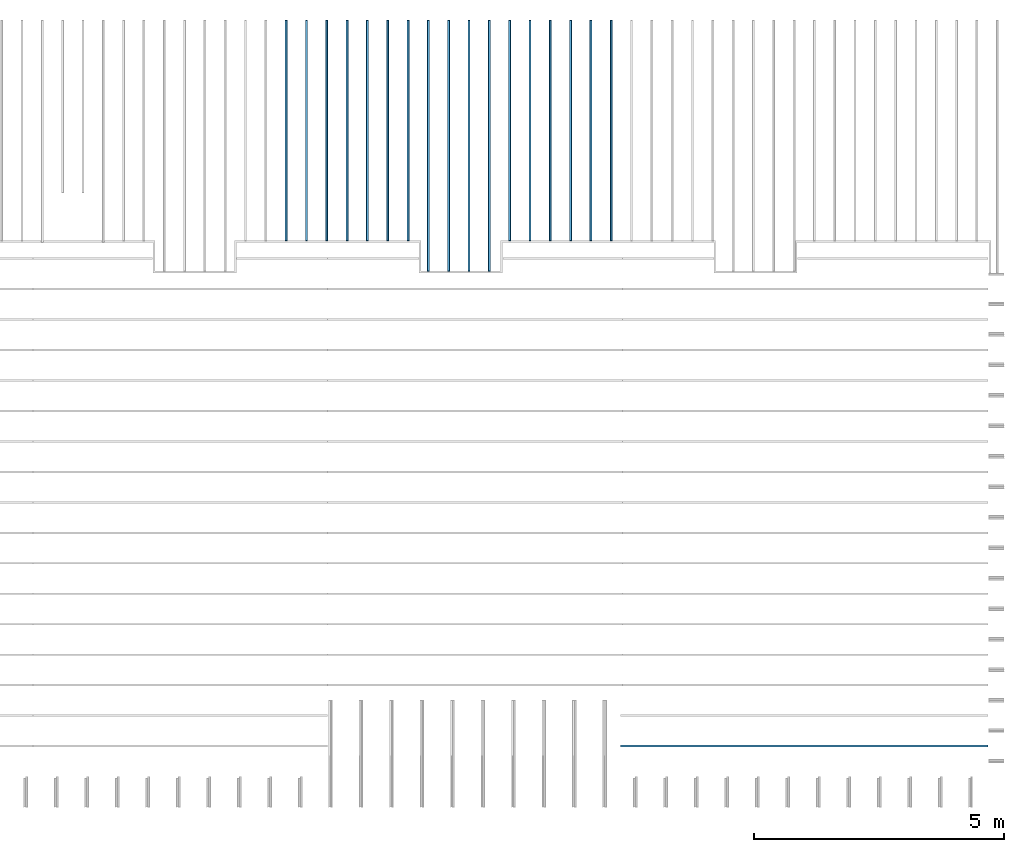
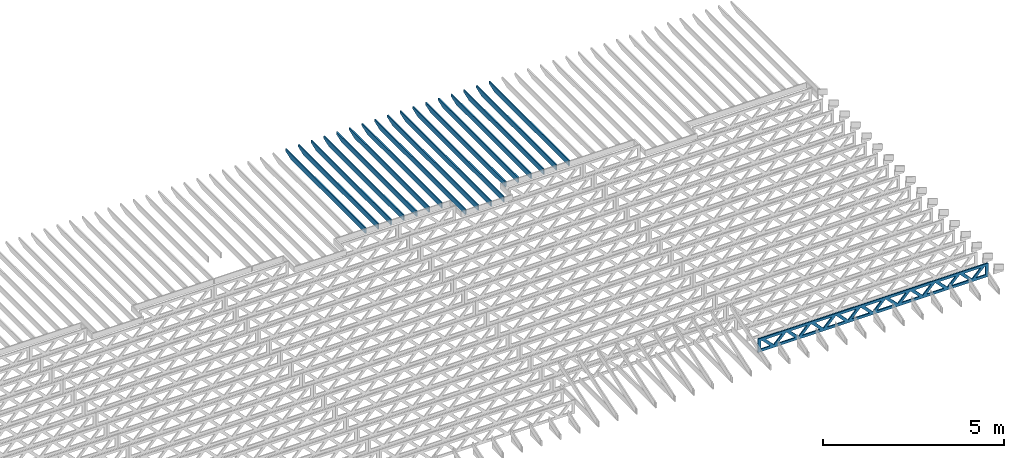
# One storey, part 11 of 18: 18 beams, 2 elements without a shape of their own.
"""IFC4 building model written with IfcOpenShell, lengths in feet."""

from ifc_helpers import new_model, entity, si_unit, converted_unit, derived_unit, direction, frame, frame_2d, origin, origin_2d_with_axis, place, context, subcontext, project, spatial, rectangle, extrude, clip, halfspace, source, transform, mapped, material, material_profile, profile_set, profile_usage, type_object, type_shapes, element, aggregate, save


model = new_model("IFC4")

# Units and contexts
model_context_1 = context("Model", 3, precision=0.0001, world=origin(), true_north=direction((6.12303176911189e-17, 1.0)))
model_context_2 = context("Model", 3, precision=0.0001, world=origin(), true_north=direction((6.12303176911189e-17, 1.0)))
body_context = subcontext(model_context_2, "Body", "Model", "MODEL_VIEW")
ifc_project = project(units=[converted_unit("LENGTHUNIT", "FOOT", entity("IfcRatioMeasure", 0.3048), si_unit("LENGTHUNIT", "METRE"), dimensions=[1, 0, 0, 0, 0, 0, 0]), converted_unit("AREAUNIT", "SQUARE FOOT", entity("IfcRatioMeasure", 0.09290304), si_unit("AREAUNIT", "SQUARE_METRE"), dimensions=[2, 0, 0, 0, 0, 0, 0]), converted_unit("VOLUMEUNIT", "CUBIC FOOT", entity("IfcRatioMeasure", 0.028316846592), si_unit("VOLUMEUNIT", "CUBIC_METRE"), dimensions=[3, 0, 0, 0, 0, 0, 0]), converted_unit("PLANEANGLEUNIT", "DEGREE", entity("IfcRatioMeasure", 0.0174532925199433), si_unit("PLANEANGLEUNIT", "RADIAN"), dimensions=[0, 0, 0, 0, 0, 0, 0]), si_unit("MASSUNIT", "GRAM", prefix="KILO"), derived_unit("MASSDENSITYUNIT", [(si_unit("MASSUNIT", "GRAM", prefix="KILO"), 1), (si_unit("LENGTHUNIT", "METRE"), -3)]), derived_unit("MOMENTOFINERTIAUNIT", [(si_unit("LENGTHUNIT", "METRE"), 4)]), si_unit("TIMEUNIT", "SECOND"), si_unit("FREQUENCYUNIT", "HERTZ"), si_unit("THERMODYNAMICTEMPERATUREUNIT", "DEGREE_CELSIUS"), derived_unit("THERMALTRANSMITTANCEUNIT", [(si_unit("MASSUNIT", "GRAM", prefix="KILO"), 1), (si_unit("THERMODYNAMICTEMPERATUREUNIT", "KELVIN"), -1), (si_unit("TIMEUNIT", "SECOND"), -3)]), derived_unit("VOLUMETRICFLOWRATEUNIT", [(si_unit("LENGTHUNIT", "METRE"), 3), (si_unit("TIMEUNIT", "SECOND"), -1)]), si_unit("ELECTRICCURRENTUNIT", "AMPERE"), si_unit("ELECTRICVOLTAGEUNIT", "VOLT"), si_unit("POWERUNIT", "WATT"), si_unit("FORCEUNIT", "NEWTON"), si_unit("ILLUMINANCEUNIT", "LUX"), si_unit("LUMINOUSFLUXUNIT", "LUMEN"), si_unit("LUMINOUSINTENSITYUNIT", "CANDELA"), derived_unit("USERDEFINED", [(si_unit("MASSUNIT", "GRAM", prefix="KILO"), -1), (si_unit("LENGTHUNIT", "METRE"), -2), (si_unit("TIMEUNIT", "SECOND"), 3), (si_unit("LUMINOUSFLUXUNIT", "LUMEN"), 1)]), derived_unit("LINEARVELOCITYUNIT", [(si_unit("LENGTHUNIT", "METRE"), 1), (si_unit("TIMEUNIT", "SECOND"), -1)]), si_unit("PRESSUREUNIT", "PASCAL"), derived_unit("USERDEFINED", [(si_unit("LENGTHUNIT", "METRE"), -2), (si_unit("MASSUNIT", "GRAM", prefix="KILO"), 1), (si_unit("TIMEUNIT", "SECOND"), -2)]), derived_unit("LINEARFORCEUNIT", [(si_unit("MASSUNIT", "GRAM", prefix="KILO"), 1), (si_unit("LENGTHUNIT", "METRE"), 1), (si_unit("TIMEUNIT", "SECOND"), -2), (si_unit("LENGTHUNIT", "METRE"), -1)]), derived_unit("PLANARFORCEUNIT", [(si_unit("MASSUNIT", "GRAM", prefix="KILO"), 1), (si_unit("LENGTHUNIT", "METRE"), 1), (si_unit("TIMEUNIT", "SECOND"), -2), (si_unit("LENGTHUNIT", "METRE"), -2)])], contexts=[model_context_1])

# Site, building, storey
site_placement = place(None, origin())
site = spatial("IfcSite", under=ifc_project, at=site_placement, CompositionType="ELEMENT")
building_placement = place(site_placement, origin())
building = spatial("IfcBuilding", under=site, at=building_placement, CompositionType="ELEMENT")
storey_placement = place(building_placement, frame((0.0, 0.0, 30.4375000000082)))
storey = spatial("IfcBuildingStorey", under=building, at=storey_placement, Name="ROOF", CompositionType="ELEMENT", Elevation=30.4375000000082)

# Assembly, beams
assembly_1_placement = place(storey_placement, origin())
assembly_1 = element("IfcElementAssembly", 1, at=assembly_1_placement, inside=storey, Name="Structural Beam System:Structural Framing System", ObjectType="Structural Beam System:Structural Framing System", AssemblyPlace="NOTDEFINED", PredefinedType="BEAM_GRID")
ifc_material_1 = material(Name="2X ROOF JOISTS - EXT. STAIN-1 - SEE LIFE SAFETY", Category="Materials")
ifc_material_profile_1 = material_profile(ifc_material_1, rectangle(XDim=0.604166666666667, YDim=0.125000000000011, at=frame_2d((0.0, 0.0), x_axis=(0.0, 1.0))))
ifc_profile_set_1 = profile_set([ifc_material_profile_1])
ifc_profile_usage_1 = profile_usage(ifc_profile_set_1, cardinal=8)
beam_type_1 = type_object("IfcBeamType", PredefinedType="BEAM", material=ifc_profile_set_1)
shared_shape_1 = source(origin(), body_context, "Body", "Clipping", [
    clip(extrude(rectangle(XDim=0.604166666666667, YDim=0.125000000000011, at=frame_2d((0.0, 0.0), x_axis=(0.0, 1.0))), frame((-8.24296473987818, 0.0, 0.0), z_axis=(1.0, 0.0, 0.0), x_axis=(0.0, 1.0, 0.0)), (0.0, 0.0, 1.0), 16.4859294797564), halfspace(frame((-7.26989982048795, -0.0625000000000026, -0.30208333333334), z_axis=(-0.34202014332567, 0.0, -0.939692620785908), x_axis=(0.0, 1.0, 0.0)), False)),
])
type_shapes(beam_type_1, [shared_shape_1])
beam_1_placement = place(assembly_1_placement, frame((-177.133993818795, 965.271566289195, 1.07291666665818), z_axis=(0.0, 0.0, 1.0), x_axis=(0.0, -1.0, 0.0)))
beam_1 = element("IfcBeam", 2, at=beam_1_placement, type_object=beam_type_1, material=ifc_profile_usage_1, PredefinedType="BEAM", context=body_context, shape_type="MappedRepresentation", body=[
    mapped(shared_shape_1, transform((0.0, 0.0, 0.0), scale=1.0)),
])
ifc_profile_usage_2 = profile_usage(ifc_profile_set_1, cardinal=8)
beam_2_placement = place(assembly_1_placement, frame((-175.800660485462, 965.271566289195, 1.07291666665817), z_axis=(0.0, 0.0, 1.0), x_axis=(0.0, -1.0, 0.0)))
beam_2 = element("IfcBeam", 3, at=beam_2_placement, type_object=beam_type_1, material=ifc_profile_usage_2, PredefinedType="BEAM", context=body_context, shape_type="MappedRepresentation", body=[
    mapped(shared_shape_1, transform((0.0, 0.0, 0.0), scale=1.0)),
])
ifc_profile_usage_3 = profile_usage(ifc_profile_set_1, cardinal=8)
beam_3_placement = place(assembly_1_placement, frame((-174.467327152128, 965.271566289195, 1.07291666665817), z_axis=(0.0, 0.0, 1.0), x_axis=(0.0, -1.0, 0.0)))
beam_3 = element("IfcBeam", 4, at=beam_3_placement, type_object=beam_type_1, material=ifc_profile_usage_3, PredefinedType="BEAM", context=body_context, shape_type="MappedRepresentation", body=[
    mapped(shared_shape_1, transform((0.0, 0.0, 0.0), scale=1.0)),
])
ifc_profile_usage_4 = profile_usage(ifc_profile_set_1, cardinal=8)
beam_4_placement = place(assembly_1_placement, frame((-173.133993818795, 965.271566289195, 1.07291666665816), z_axis=(0.0, 0.0, 1.0), x_axis=(0.0, -1.0, 0.0)))
beam_4 = element("IfcBeam", 5, at=beam_4_placement, type_object=beam_type_1, material=ifc_profile_usage_4, PredefinedType="BEAM", context=body_context, shape_type="MappedRepresentation", body=[
    mapped(shared_shape_1, transform((0.0, 0.0, 0.0), scale=1.0)),
])
ifc_profile_usage_5 = profile_usage(ifc_profile_set_1, cardinal=8)
beam_type_2 = type_object("IfcBeamType", PredefinedType="BEAM", material=ifc_profile_set_1)
shared_shape_2 = source(origin(), body_context, "Body", "Clipping", [
    clip(extrude(rectangle(XDim=0.604166666666667, YDim=0.125000000000011, at=frame_2d((0.0, 0.0), x_axis=(0.0, 1.0))), frame((-7.24296407101895, 0.0, 0.0), z_axis=(1.0, 0.0, 0.0), x_axis=(0.0, 1.0, 0.0)), (0.0, 0.0, 1.0), 14.4859281420379), halfspace(frame((-6.26989915162872, -0.0625000000000026, -0.30208333333334), z_axis=(-0.34202014332567, 0.0, -0.939692620785908), x_axis=(0.0, 1.0, 0.0)), False)),
])
type_shapes(beam_type_2, [shared_shape_2])
beam_5_placement = place(assembly_1_placement, frame((-186.467327152128, 966.271566958054, 1.0729166666583), z_axis=(0.0, 0.0, 1.0), x_axis=(0.0, -1.0, 0.0)))
beam_5 = element("IfcBeam", 6, at=beam_5_placement, type_object=beam_type_2, material=ifc_profile_usage_5, PredefinedType="BEAM", context=body_context, shape_type="MappedRepresentation", body=[
    mapped(shared_shape_2, transform((0.0, 0.0, 0.0), scale=1.0)),
])
ifc_profile_usage_6 = profile_usage(ifc_profile_set_1, cardinal=8)
beam_type_3 = type_object("IfcBeamType", PredefinedType="BEAM", material=ifc_profile_set_1)
shared_shape_3 = source(origin(), body_context, "Body", "Clipping", [
    clip(extrude(rectangle(XDim=0.604166666666667, YDim=0.125000000000011, at=frame_2d((0.0, 0.0), x_axis=(0.0, 1.0))), frame((-7.24296378214677, 0.0, 0.0), z_axis=(1.0, 0.0, 0.0), x_axis=(0.0, 1.0, 0.0)), (0.0, 0.0, 1.0), 14.4859275642935), halfspace(frame((-6.26989886275655, -0.0625000000000026, -0.30208333333334), z_axis=(-0.34202014332567, 0.0, -0.939692620785908), x_axis=(0.0, 1.0, 0.0)), False)),
])
type_shapes(beam_type_3, [shared_shape_3])
beam_6_placement = place(assembly_1_placement, frame((-183.800660485462, 966.271567258244, 1.0729166666583), z_axis=(0.0, 0.0, 1.0), x_axis=(0.0, -1.0, 0.0)))
beam_6 = element("IfcBeam", 7, at=beam_6_placement, type_object=beam_type_3, material=ifc_profile_usage_6, PredefinedType="BEAM", context=body_context, shape_type="MappedRepresentation", body=[
    mapped(shared_shape_3, transform((0.0, 0.0, 0.0), scale=1.0)),
])
ifc_profile_usage_7 = profile_usage(ifc_profile_set_1, cardinal=8)
beam_type_4 = type_object("IfcBeamType", PredefinedType="BEAM", material=ifc_profile_set_1)
shared_shape_4 = source(origin(), body_context, "Body", "Clipping", [
    clip(extrude(rectangle(XDim=0.604166666666667, YDim=0.125000000000011, at=frame_2d((0.0, 0.0), x_axis=(0.0, 1.0))), frame((-7.24296332054621, 0.0, 0.0), z_axis=(1.0, 0.0, 0.0), x_axis=(0.0, 1.0, 0.0)), (0.0, 0.0, 1.0), 14.4859266410924), halfspace(frame((-6.26989840115598, -0.0625000000000026, -0.30208333333334), z_axis=(-0.34202014332567, 0.0, -0.939692620785908), x_axis=(0.0, 1.0, 0.0)), False)),
])
type_shapes(beam_type_4, [shared_shape_4])
beam_7_placement = place(assembly_1_placement, frame((-179.800660485462, 966.271567708527, 1.07291666665829), z_axis=(0.0, 0.0, 1.0), x_axis=(0.0, -1.0, 0.0)))
beam_7 = element("IfcBeam", 8, at=beam_7_placement, type_object=beam_type_4, material=ifc_profile_usage_7, PredefinedType="BEAM", context=body_context, shape_type="MappedRepresentation", body=[
    mapped(shared_shape_4, transform((0.0, 0.0, 0.0), scale=1.0)),
])
ifc_profile_usage_8 = profile_usage(ifc_profile_set_1, cardinal=8)
beam_type_5 = type_object("IfcBeamType", PredefinedType="BEAM", material=ifc_profile_set_1)
shared_shape_5 = source(origin(), body_context, "Body", "Clipping", [
    clip(extrude(rectangle(XDim=0.604166666666667, YDim=0.125000000000011, at=frame_2d((0.0, 0.0), x_axis=(0.0, 1.0))), frame((-7.24296317045162, 0.0, 0.0), z_axis=(1.0, 0.0, 0.0), x_axis=(0.0, 1.0, 0.0)), (0.0, 0.0, 1.0), 14.4859263409032), halfspace(frame((-6.26989825106139, -0.0625000000000026, -0.30208333333334), z_axis=(-0.34202014332567, 0.0, -0.939692620785908), x_axis=(0.0, 1.0, 0.0)), False)),
])
type_shapes(beam_type_5, [shared_shape_5])
beam_8_placement = place(assembly_1_placement, frame((-178.467327152128, 966.271567858622, 1.07291666665829), z_axis=(0.0, 0.0, 1.0), x_axis=(0.0, -1.0, 0.0)))
beam_8 = element("IfcBeam", 9, at=beam_8_placement, type_object=beam_type_5, material=ifc_profile_usage_8, PredefinedType="BEAM", context=body_context, shape_type="MappedRepresentation", body=[
    mapped(shared_shape_5, transform((0.0, 0.0, 0.0), scale=1.0)),
])
ifc_profile_usage_9 = profile_usage(ifc_profile_set_1, cardinal=8)
beam_type_6 = type_object("IfcBeamType", PredefinedType="BEAM", material=ifc_profile_set_1)
shared_shape_6 = source(origin(), body_context, "Body", "Clipping", [
    clip(extrude(rectangle(XDim=0.604166666666667, YDim=0.125000000000011, at=frame_2d((0.0, 0.0), x_axis=(0.0, 1.0))), frame((-7.24296392092435, 0.0, 0.0), z_axis=(1.0, 0.0, 0.0), x_axis=(0.0, 1.0, 0.0)), (0.0, 0.0, 1.0), 14.4859278418487), halfspace(frame((-6.26989900153413, -0.0625000000000026, -0.30208333333334), z_axis=(-0.34202014332567, 0.0, -0.939692620785908), x_axis=(0.0, 1.0, 0.0)), False)),
])
type_shapes(beam_type_6, [shared_shape_6])
beam_9_placement = place(assembly_1_placement, frame((-185.133993818795, 966.271567108149, 1.0729166666583), z_axis=(0.0, 0.0, 1.0), x_axis=(0.0, -1.0, 0.0)))
beam_9 = element("IfcBeam", 10, at=beam_9_placement, type_object=beam_type_6, material=ifc_profile_usage_9, PredefinedType="BEAM", context=body_context, shape_type="MappedRepresentation", body=[
    mapped(shared_shape_6, transform((0.0, 0.0, 0.0), scale=1.0)),
])
ifc_profile_usage_10 = profile_usage(ifc_profile_set_1, cardinal=8)
beam_type_7 = type_object("IfcBeamType", PredefinedType="BEAM", material=ifc_profile_set_1)
shared_shape_7 = source(origin(), body_context, "Body", "Clipping", [
    clip(extrude(rectangle(XDim=0.604166666666667, YDim=0.125000000000011, at=frame_2d((0.0, 0.0), x_axis=(0.0, 1.0))), frame((-7.24296361464559, 0.0, 0.0), z_axis=(1.0, 0.0, 0.0), x_axis=(0.0, 1.0, 0.0)), (0.0, 0.0, 1.0), 14.4859272292912), halfspace(frame((-6.26989869525536, -0.0625000000000026, -0.30208333333334), z_axis=(-0.34202014332567, 0.0, -0.939692620785908), x_axis=(0.0, 1.0, 0.0)), False)),
])
type_shapes(beam_type_7, [shared_shape_7])
beam_10_placement = place(assembly_1_placement, frame((-182.467327152128, 966.271567408338, 1.0729166666583), z_axis=(0.0, 0.0, 1.0), x_axis=(0.0, -1.0, 0.0)))
beam_10 = element("IfcBeam", 11, at=beam_10_placement, type_object=beam_type_7, material=ifc_profile_usage_10, PredefinedType="BEAM", context=body_context, shape_type="MappedRepresentation", body=[
    mapped(shared_shape_7, transform((0.0, 0.0, 0.0), scale=1.0)),
])
ifc_profile_usage_11 = profile_usage(ifc_profile_set_1, cardinal=8)
beam_type_8 = type_object("IfcBeamType", PredefinedType="BEAM", material=ifc_profile_set_1)
shared_shape_8 = source(origin(), body_context, "Body", "Clipping", [
    clip(extrude(rectangle(XDim=0.604166666666667, YDim=0.125000000000011, at=frame_2d((0.0, 0.0), x_axis=(0.0, 1.0))), frame((-7.24296495465501, 0.0, 0.0), z_axis=(1.0, 0.0, 0.0), x_axis=(0.0, 1.0, 0.0)), (0.0, 0.0, 1.0), 14.48592990931), halfspace(frame((-6.26990003526478, -0.0625000000000026, -0.30208333333334), z_axis=(-0.34202014332567, 0.0, -0.939692620785908), x_axis=(0.0, 1.0, 0.0)), False)),
])
type_shapes(beam_type_8, [shared_shape_8])
beam_11_placement = place(assembly_1_placement, frame((-170.467327152128, 966.271566074418, 1.07291666665829), z_axis=(0.0, 0.0, 1.0), x_axis=(0.0, -1.0, 0.0)))
beam_11 = element("IfcBeam", 12, at=beam_11_placement, type_object=beam_type_8, material=ifc_profile_usage_11, PredefinedType="BEAM", context=body_context, shape_type="MappedRepresentation", body=[
    mapped(shared_shape_8, transform((0.0, 0.0, 0.0), scale=1.0)),
])
ifc_profile_usage_12 = profile_usage(ifc_profile_set_1, cardinal=8)
beam_type_9 = type_object("IfcBeamType", PredefinedType="BEAM", material=ifc_profile_set_1)
shared_shape_9 = source(origin(), body_context, "Body", "Clipping", [
    clip(extrude(rectangle(XDim=0.604166666666667, YDim=0.125000000000011, at=frame_2d((0.0, 0.0), x_axis=(0.0, 1.0))), frame((-7.2429646196527, 0.0, 0.0), z_axis=(1.0, 0.0, 0.0), x_axis=(0.0, 1.0, 0.0)), (0.0, 0.0, 1.0), 14.4859292393054), halfspace(frame((-6.26989970026247, -0.0625000000000026, -0.30208333333334), z_axis=(-0.34202014332567, 0.0, -0.939692620785908), x_axis=(0.0, 1.0, 0.0)), False)),
])
type_shapes(beam_type_9, [shared_shape_9])
beam_12_placement = place(assembly_1_placement, frame((-167.800660485462, 966.271566409421, 1.07291666665829), z_axis=(0.0, 0.0, 1.0), x_axis=(0.0, -1.0, 0.0)))
beam_12 = element("IfcBeam", 13, at=beam_12_placement, type_object=beam_type_9, material=ifc_profile_usage_12, PredefinedType="BEAM", context=body_context, shape_type="MappedRepresentation", body=[
    mapped(shared_shape_9, transform((0.0, 0.0, 0.0), scale=1.0)),
])
ifc_profile_usage_13 = profile_usage(ifc_profile_set_1, cardinal=8)
beam_type_10 = type_object("IfcBeamType", PredefinedType="BEAM", material=ifc_profile_set_1)
shared_shape_10 = source(origin(), body_context, "Body", "Clipping", [
    clip(extrude(rectangle(XDim=0.604166666666667, YDim=0.125000000000011, at=frame_2d((0.0, 0.0), x_axis=(0.0, 1.0))), frame((-7.24296428465033, 0.0, 0.0), z_axis=(1.0, 0.0, 0.0), x_axis=(0.0, 1.0, 0.0)), (0.0, 0.0, 1.0), 14.4859285693007), halfspace(frame((-6.2698993652601, -0.0625000000000026, -0.30208333333334), z_axis=(-0.34202014332567, 0.0, -0.939692620785908), x_axis=(0.0, 1.0, 0.0)), False)),
])
type_shapes(beam_type_10, [shared_shape_10])
beam_13_placement = place(assembly_1_placement, frame((-165.133993818795, 966.271566744423, 1.07291666665829), z_axis=(0.0, 0.0, 1.0), x_axis=(0.0, -1.0, 0.0)))
beam_13 = element("IfcBeam", 14, at=beam_13_placement, type_object=beam_type_10, material=ifc_profile_usage_13, PredefinedType="BEAM", context=body_context, shape_type="MappedRepresentation", body=[
    mapped(shared_shape_10, transform((0.0, 0.0, 0.0), scale=1.0)),
])
ifc_profile_usage_14 = profile_usage(ifc_profile_set_1, cardinal=8)
beam_type_11 = type_object("IfcBeamType", PredefinedType="BEAM", material=ifc_profile_set_1)
shared_shape_11 = source(origin(), body_context, "Body", "Clipping", [
    clip(extrude(rectangle(XDim=0.604166666666667, YDim=0.125000000000011, at=frame_2d((0.0, 0.0), x_axis=(0.0, 1.0))), frame((-7.24296445215151, 0.0, 0.0), z_axis=(1.0, 0.0, 0.0), x_axis=(0.0, 1.0, 0.0)), (0.0, 0.0, 1.0), 14.485928904303), halfspace(frame((-6.26989953276129, -0.0625000000000026, -0.30208333333334), z_axis=(-0.34202014332567, 0.0, -0.939692620785908), x_axis=(0.0, 1.0, 0.0)), False)),
])
type_shapes(beam_type_11, [shared_shape_11])
beam_14_placement = place(assembly_1_placement, frame((-166.467327152128, 966.271566576922, 1.07291666665829), z_axis=(0.0, 0.0, 1.0), x_axis=(0.0, -1.0, 0.0)))
beam_14 = element("IfcBeam", 15, at=beam_14_placement, type_object=beam_type_11, material=ifc_profile_usage_14, PredefinedType="BEAM", context=body_context, shape_type="MappedRepresentation", body=[
    mapped(shared_shape_11, transform((0.0, 0.0, 0.0), scale=1.0)),
])
ifc_profile_usage_15 = profile_usage(ifc_profile_set_1, cardinal=8)
beam_type_12 = type_object("IfcBeamType", PredefinedType="BEAM", material=ifc_profile_set_1)
shared_shape_12 = source(origin(), body_context, "Body", "Clipping", [
    clip(extrude(rectangle(XDim=0.604166666666667, YDim=0.125000000000011, at=frame_2d((0.0, 0.0), x_axis=(0.0, 1.0))), frame((-7.24296478715382, 0.0, 0.0), z_axis=(1.0, 0.0, 0.0), x_axis=(0.0, 1.0, 0.0)), (0.0, 0.0, 1.0), 14.4859295743076), halfspace(frame((-6.2698998677636, -0.0625000000000026, -0.30208333333334), z_axis=(-0.34202014332567, 0.0, -0.939692620785908), x_axis=(0.0, 1.0, 0.0)), False)),
])
type_shapes(beam_type_12, [shared_shape_12])
beam_15_placement = place(assembly_1_placement, frame((-169.133993818795, 966.271566241919, 1.07291666665829), z_axis=(0.0, 0.0, 1.0), x_axis=(0.0, -1.0, 0.0)))
beam_15 = element("IfcBeam", 16, at=beam_15_placement, type_object=beam_type_12, material=ifc_profile_usage_15, PredefinedType="BEAM", context=body_context, shape_type="MappedRepresentation", body=[
    mapped(shared_shape_12, transform((0.0, 0.0, 0.0), scale=1.0)),
])
ifc_profile_usage_16 = profile_usage(ifc_profile_set_1, cardinal=8)
beam_type_13 = type_object("IfcBeamType", PredefinedType="BEAM", material=ifc_profile_set_1)
shared_shape_13 = source(origin(), body_context, "Body", "Clipping", [
    clip(extrude(rectangle(XDim=0.604166666666667, YDim=0.125000000000011, at=frame_2d((0.0, 0.0), x_axis=(0.0, 1.0))), frame((-7.24296512215625, 0.0, 0.0), z_axis=(1.0, 0.0, 0.0), x_axis=(0.0, 1.0, 0.0)), (0.0, 0.0, 1.0), 14.4859302443125), halfspace(frame((-6.26990020276602, -0.0625000000000026, -0.30208333333334), z_axis=(-0.34202014332567, 0.0, -0.939692620785908), x_axis=(0.0, 1.0, 0.0)), False)),
])
type_shapes(beam_type_13, [shared_shape_13])
beam_16_placement = place(assembly_1_placement, frame((-171.800660485462, 966.271565906917, 1.07291666665829), z_axis=(0.0, 0.0, 1.0), x_axis=(0.0, -1.0, 0.0)))
beam_16 = element("IfcBeam", 17, at=beam_16_placement, type_object=beam_type_13, material=ifc_profile_usage_16, PredefinedType="BEAM", context=body_context, shape_type="MappedRepresentation", body=[
    mapped(shared_shape_13, transform((0.0, 0.0, 0.0), scale=1.0)),
])
ifc_profile_usage_17 = profile_usage(ifc_profile_set_1, cardinal=8)
beam_type_14 = type_object("IfcBeamType", PredefinedType="BEAM", material=ifc_profile_set_1)
shared_shape_14 = source(origin(), body_context, "Body", "Clipping", [
    clip(extrude(rectangle(XDim=0.604166666666667, YDim=0.125000000000011, at=frame_2d((0.0, -5.55111512312578e-17), x_axis=(0.0, 1.0))), frame((-7.24296347064075, 0.0, 0.0), z_axis=(1.0, 0.0, 0.0), x_axis=(0.0, 1.0, 0.0)), (0.0, 0.0, 1.0), 14.4859269412815), halfspace(frame((-6.26989855125052, -0.0625000000000026, -0.30208333333334), z_axis=(-0.34202014332567, 0.0, -0.939692620785908), x_axis=(0.0, 1.0, 0.0)), False)),
])
type_shapes(beam_type_14, [shared_shape_14])
beam_17_placement = place(assembly_1_placement, frame((-181.133993818795, 966.271567558433, 1.07291666665829), z_axis=(0.0, 0.0, 1.0), x_axis=(0.0, -1.0, 0.0)))
beam_17 = element("IfcBeam", 18, at=beam_17_placement, type_object=beam_type_14, material=ifc_profile_usage_17, PredefinedType="BEAM", context=body_context, shape_type="MappedRepresentation", body=[
    mapped(shared_shape_14, transform((0.0, 0.0, 0.0), scale=1.0)),
])
aggregate(assembly_1, [beam_5, beam_9, beam_6, beam_10, beam_8, beam_1, beam_2, beam_3, beam_11, beam_12, beam_13, beam_14, beam_15, beam_16, beam_4, beam_7, beam_17])

# Assembly, beam
assembly_2_placement = place(storey_placement, origin())
assembly_2 = element("IfcElementAssembly", 19, at=assembly_2_placement, inside=storey, Name="Structural Beam System:Structural Framing System", ObjectType="Structural Beam System:Structural Framing System", AssemblyPlace="NOTDEFINED", PredefinedType="BEAM_GRID")
ifc_material_2 = material(Name="WOOD TRUSS", Category="Materials")
ifc_material_profile_2 = material_profile(ifc_material_2, rectangle(XDim=1.73473973950632, YDim=0.125, at=origin_2d_with_axis()))
ifc_material_profile_3 = material_profile(ifc_material_2, rectangle(XDim=1.73473973950633, YDim=0.125, at=frame_2d((-1.11022302462516e-16, 0.0), x_axis=(1.0, 0.0))))
ifc_material_profile_4 = material_profile(ifc_material_2, rectangle(XDim=1.73473973950632, YDim=0.125, at=origin_2d_with_axis()))
ifc_material_profile_5 = material_profile(ifc_material_2, rectangle(XDim=1.73473973950633, YDim=0.125, at=origin_2d_with_axis()))
ifc_material_profile_6 = material_profile(ifc_material_2, rectangle(XDim=1.73473973950632, YDim=0.125, at=frame_2d((-5.55111512312578e-17, 0.0), x_axis=(1.0, 0.0))))
ifc_material_profile_7 = material_profile(ifc_material_2, rectangle(XDim=1.73473973950633, YDim=0.125, at=frame_2d((-2.77555756156289e-16, 0.0), x_axis=(1.0, 0.0))))
ifc_material_profile_8 = material_profile(ifc_material_2, rectangle(XDim=1.73473973950632, YDim=0.125, at=frame_2d((-4.9960036108132e-16, 0.0), x_axis=(1.0, 0.0))))
ifc_material_profile_9 = material_profile(ifc_material_2, rectangle(XDim=1.73473973950633, YDim=0.125, at=frame_2d((4.44089209850063e-16, 0.0), x_axis=(1.0, 0.0))))
ifc_material_profile_10 = material_profile(ifc_material_2, rectangle(XDim=1.73473973950632, YDim=0.125, at=origin_2d_with_axis()))
ifc_material_profile_11 = material_profile(ifc_material_2, rectangle(XDim=1.73473973950633, YDim=0.125, at=frame_2d((-4.9960036108132e-16, 0.0), x_axis=(1.0, 0.0))))
ifc_material_profile_12 = material_profile(ifc_material_2, rectangle(XDim=0.291666666666664, YDim=0.125, at=frame_2d((-2.77555756156289e-17, 0.0), x_axis=(1.0, 0.0))))
ifc_material_profile_13 = material_profile(ifc_material_2, rectangle(XDim=0.291666666666628, YDim=0.124999999999995, at=frame_2d((-5.55111512312578e-17, 0.0), x_axis=(1.0, 0.0))))
ifc_material_profile_14 = material_profile(ifc_material_2, rectangle(XDim=0.916666666666666, YDim=0.125000000000003, at=frame_2d((-2.77555756156289e-17, 0.0), x_axis=(1.0, 0.0))))
ifc_material_profile_15 = material_profile(ifc_material_2, rectangle(XDim=0.916666666666651, YDim=0.125, at=frame_2d((-2.77555756156289e-17, 0.0), x_axis=(1.0, 0.0))))
ifc_profile_set_2 = profile_set([ifc_material_profile_2, ifc_material_profile_3, ifc_material_profile_4, ifc_material_profile_5, ifc_material_profile_6, ifc_material_profile_7, ifc_material_profile_8, ifc_material_profile_9, ifc_material_profile_10, ifc_material_profile_11, ifc_material_profile_12, ifc_material_profile_13, ifc_material_profile_14, ifc_material_profile_15])
ifc_profile_usage_18 = profile_usage(ifc_profile_set_2, cardinal=8)
beam_type_15 = type_object("IfcBeamType", PredefinedType="BEAM", material=ifc_profile_set_2)
shared_shape_15 = source(origin(), body_context, "Body", "SweptSolid", [
    extrude(rectangle(XDim=1.73473973950632, YDim=0.125, at=frame_2d((8.88178419700125e-16, 0.0), x_axis=(1.0, 0.0))), frame((8.31693784968716, 0.0, 0.101118361020562), z_axis=(0.720569184836762, 0.0, -0.693383046997606), x_axis=(0.693383046997606, 0.0, 0.720569184836762)), (0.0, 0.0, 1.0), 0.291666666666667),
    extrude(rectangle(XDim=1.73473973950633, YDim=0.125, at=frame_2d((4.9960036108132e-16, 0.0), x_axis=(1.0, 0.0))), frame((7.06665197601389, 0.0, -0.101118361020407), z_axis=(0.720569184836758, 0.0, 0.69338304699761), x_axis=(0.69338304699761, 0.0, -0.720569184836758)), (0.0, 0.0, 1.0), 0.291666666666667),
    extrude(rectangle(XDim=1.73473973950632, YDim=0.125, at=origin_2d_with_axis()), frame((5.71797854336309, 0.0, 0.101118361020562), z_axis=(0.720569184836762, 0.0, -0.693383046997606), x_axis=(0.693383046997606, 0.0, 0.720569184836762)), (0.0, 0.0, 1.0), 0.291666666666667),
    extrude(rectangle(XDim=1.73473973950633, YDim=0.125, at=frame_2d((-4.9960036108132e-16, 0.0), x_axis=(1.0, 0.0))), frame((4.46769266968982, 0.0, -0.101118361020407), z_axis=(0.720569184836758, 0.0, 0.69338304699761), x_axis=(0.69338304699761, 0.0, -0.720569184836758)), (0.0, 0.0, 1.0), 0.291666666666667),
    extrude(rectangle(XDim=1.73473973950632, YDim=0.125, at=frame_2d((3.33066907387547e-16, 0.0), x_axis=(1.0, 0.0))), frame((3.11901923703901, 0.0, 0.101118361020562), z_axis=(0.720569184836762, 0.0, -0.693383046997606), x_axis=(0.693383046997606, 0.0, 0.720569184836762)), (0.0, 0.0, 1.0), 0.291666666666667),
    extrude(rectangle(XDim=1.73473973950633, YDim=0.125, at=frame_2d((-1.11022302462516e-16, 0.0), x_axis=(1.0, 0.0))), frame((1.86873336336574, 0.0, -0.101118361020407), z_axis=(0.720569184836758, 0.0, 0.69338304699761), x_axis=(0.69338304699761, 0.0, -0.720569184836758)), (0.0, 0.0, 1.0), 0.291666666666666),
    extrude(rectangle(XDim=1.73473973950632, YDim=0.125, at=frame_2d((5.55111512312578e-17, 0.0), x_axis=(1.0, 0.0))), frame((0.520059930714937, 0.0, 0.101118361020562), z_axis=(0.720569184836762, 0.0, -0.693383046997606), x_axis=(0.693383046997606, 0.0, 0.720569184836762)), (0.0, 0.0, 1.0), 0.291666666666667),
    extrude(rectangle(XDim=1.73473973950633, YDim=0.125, at=origin_2d_with_axis()), frame((-0.730225942958334, 0.0, -0.101118361020407), z_axis=(0.720569184836758, 0.0, 0.69338304699761), x_axis=(0.69338304699761, 0.0, -0.720569184836758)), (0.0, 0.0, 1.0), 0.291666666666666),
    extrude(rectangle(XDim=1.73473973950632, YDim=0.125, at=frame_2d((-5.55111512312578e-17, 0.0), x_axis=(1.0, 0.0))), frame((-2.07889937560914, 0.0, 0.101118361020562), z_axis=(0.720569184836762, 0.0, -0.693383046997606), x_axis=(0.693383046997606, 0.0, 0.720569184836762)), (0.0, 0.0, 1.0), 0.291666666666667),
    extrude(rectangle(XDim=1.73473973950633, YDim=0.125, at=frame_2d((-2.77555756156289e-16, 0.0), x_axis=(1.0, 0.0))), frame((-3.32918524928241, 0.0, -0.101118361020407), z_axis=(0.720569184836758, 0.0, 0.69338304699761), x_axis=(0.69338304699761, 0.0, -0.720569184836758)), (0.0, 0.0, 1.0), 0.291666666666666),
    extrude(rectangle(XDim=1.73473973950632, YDim=0.125, at=origin_2d_with_axis()), frame((-4.67785868193321, 0.0, 0.101118361020562), z_axis=(0.720569184836762, 0.0, -0.693383046997606), x_axis=(0.693383046997606, 0.0, 0.720569184836762)), (0.0, 0.0, 1.0), 0.291666666666667),
    extrude(rectangle(XDim=1.73473973950633, YDim=0.125, at=frame_2d((-4.9960036108132e-16, 0.0), x_axis=(1.0, 0.0))), frame((-5.92814455560648, 0.0, -0.101118361020407), z_axis=(0.720569184836758, 0.0, 0.69338304699761), x_axis=(0.69338304699761, 0.0, -0.720569184836758)), (0.0, 0.0, 1.0), 0.291666666666667),
    extrude(rectangle(XDim=1.73473973950632, YDim=0.125, at=frame_2d((-5.55111512312578e-16, 0.0), x_axis=(1.0, 0.0))), frame((-7.27681798825729, 0.0, 0.101118361020562), z_axis=(0.720569184836762, 0.0, -0.693383046997606), x_axis=(0.693383046997606, 0.0, 0.720569184836762)), (0.0, 0.0, 1.0), 0.291666666666667),
    extrude(rectangle(XDim=1.73473973950633, YDim=0.125, at=origin_2d_with_axis()), frame((-8.52710386193056, 0.0, -0.101118361020407), z_axis=(0.720569184836758, 0.0, 0.69338304699761), x_axis=(0.69338304699761, 0.0, -0.720569184836758)), (0.0, 0.0, 1.0), 0.291666666666666),
    extrude(rectangle(XDim=1.73473973950632, YDim=0.125, at=frame_2d((-1.0547118733939e-15, 0.0), x_axis=(1.0, 0.0))), frame((10.9158971560112, 0.0, 0.101118361020503), z_axis=(0.720569184836762, 0.0, -0.693383046997606), x_axis=(0.693383046997606, 0.0, 0.720569184836762)), (0.0, 0.0, 1.0), 0.291666666666664),
    extrude(rectangle(XDim=1.73473973950633, YDim=0.125, at=origin_2d_with_axis()), frame((9.66561128233796, 0.0, -0.101118361020466), z_axis=(0.720569184836758, 0.0, 0.69338304699761), x_axis=(0.69338304699761, 0.0, -0.720569184836758)), (0.0, 0.0, 1.0), 0.291666666666666),
    extrude(rectangle(XDim=1.73473973950632, YDim=0.125, at=frame_2d((9.43689570931383e-16, 0.0), x_axis=(1.0, 0.0))), frame((-9.87577729458136, 0.0, 0.101118361020564), z_axis=(0.720569184836762, 0.0, -0.693383046997606), x_axis=(0.693383046997606, 0.0, 0.720569184836762)), (0.0, 0.0, 1.0), 0.291666666666667),
    extrude(rectangle(XDim=1.73473973950633, YDim=0.125, at=origin_2d_with_axis()), frame((-11.1260631682546, 0.0, -0.101118361020405), z_axis=(0.720569184836758, 0.0, 0.69338304699761), x_axis=(0.69338304699761, 0.0, -0.720569184836758)), (0.0, 0.0, 1.0), 0.291666666666666),
    extrude(rectangle(XDim=0.291666666666664, YDim=0.125, at=frame_2d((-2.77555756156289e-17, 0.0), x_axis=(1.0, 0.0))), frame((-12.0625038919629, 0.0, 0.604166666666611), z_axis=(1.0, 0.0, 0.0), x_axis=(0.0, 0.0, -1.0)), (0.0, 0.0, 1.0), 24.1250077839258),
    extrude(rectangle(XDim=0.291666666666628, YDim=0.124999999999995, at=frame_2d((-5.55111512312578e-17, 0.0), x_axis=(1.0, 0.0))), frame((-12.0625038919627, 0.0, -0.604166666666693), z_axis=(1.0, 0.0, 0.0), x_axis=(0.0, 0.0, -1.0)), (0.0, 0.0, 1.0), 24.1250077839255),
    extrude(rectangle(XDim=0.916666666666666, YDim=0.125000000000003, at=frame_2d((-2.77555756156289e-17, 0.0), x_axis=(1.0, 0.0))), frame((11.7708372252962, 0.0, 0.0), z_axis=(1.0, 0.0, 0.0), x_axis=(0.0, 0.0, -1.0)), (0.0, 0.0, 1.0), 0.291666666666687),
    extrude(rectangle(XDim=0.916666666666651, YDim=0.125, at=frame_2d((-2.77555756156289e-17, -6.93889390390723e-18), x_axis=(1.0, 0.0))), frame((-12.0625038919629, 0.0, 0.0), z_axis=(1.0, 0.0, 0.0), x_axis=(0.0, 0.0, -1.0)), (0.0, 0.0, 1.0), 0.291666666666687),
])
type_shapes(beam_type_15, [shared_shape_15])
beam_18_placement = place(assembly_2_placement, frame((-152.4673232603, 925.861934882651, 0.749999999991701), z_axis=(0.0, 0.0, 1.0), x_axis=(-1.0, 0.0, 0.0)))
beam_18 = element("IfcBeam", 20, at=beam_18_placement, type_object=beam_type_15, material=ifc_profile_usage_18, PredefinedType="BEAM", context=body_context, shape_type="MappedRepresentation", body=[
    mapped(shared_shape_15, transform((0.0, 0.0, 0.0), scale=1.0)),
])
aggregate(assembly_2, [beam_18])

save(model, "model.ifc")
